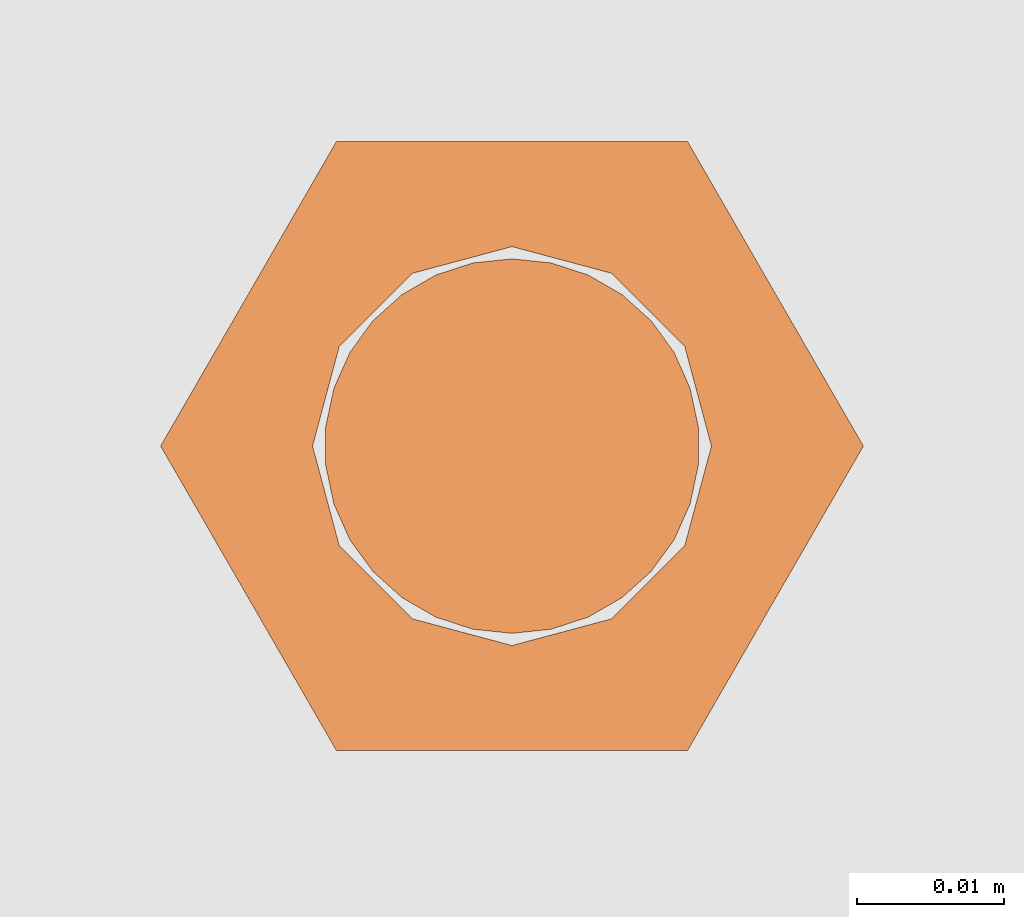
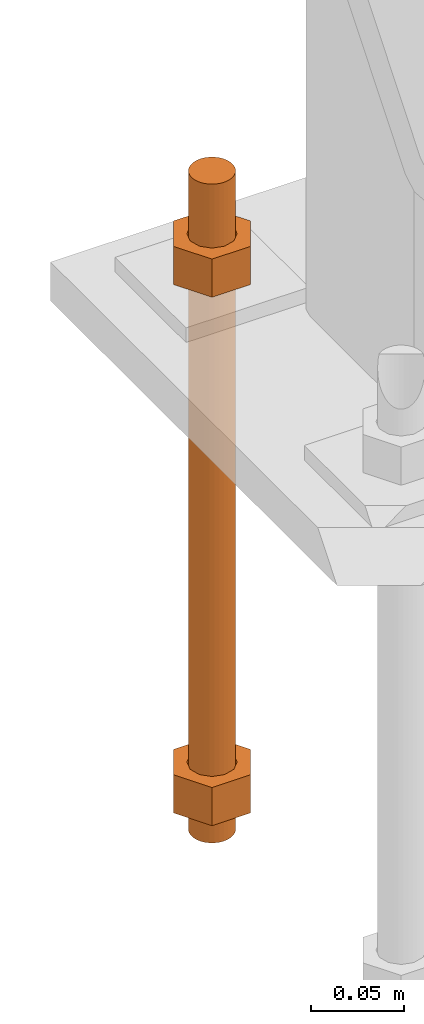
# One storey, part 25 of 89: 1 proxy.
"""IFC4 building model written with IfcOpenShell, lengths in feet."""

from ifc_helpers import new_model, entity, si_unit, converted_unit, derived_unit, direction, frame, origin, place, context, subcontext, project, spatial, faceted_brep, source, transform, mapped, material, constituent, constituent_set, type_object, type_shapes, element, save


model = new_model("IFC4")

# Units and contexts
model_context = context("Model", 3, precision=0.0001, world=origin(), true_north=direction((6.12303176911189e-17, 1.0)))
body_context = subcontext(model_context, "Body", "Model", "MODEL_VIEW")
ifc_project = project(units=[converted_unit("LENGTHUNIT", "FOOT", entity("IfcRatioMeasure", 0.3048), si_unit("LENGTHUNIT", "METRE"), dimensions=[1, 0, 0, 0, 0, 0, 0]), converted_unit("AREAUNIT", "SQUARE FOOT", entity("IfcRatioMeasure", 0.09290304), si_unit("AREAUNIT", "SQUARE_METRE"), dimensions=[2, 0, 0, 0, 0, 0, 0]), converted_unit("VOLUMEUNIT", "CUBIC FOOT", entity("IfcRatioMeasure", 0.028316846592), si_unit("VOLUMEUNIT", "CUBIC_METRE"), dimensions=[3, 0, 0, 0, 0, 0, 0]), si_unit("PLANEANGLEUNIT", "RADIAN"), si_unit("MASSUNIT", "GRAM", prefix="KILO"), derived_unit("MASSDENSITYUNIT", [(si_unit("MASSUNIT", "GRAM", prefix="KILO"), 1), (si_unit("LENGTHUNIT", "METRE"), -3)]), derived_unit("MOMENTOFINERTIAUNIT", [(si_unit("LENGTHUNIT", "METRE"), 4)]), si_unit("TIMEUNIT", "SECOND"), si_unit("FREQUENCYUNIT", "HERTZ"), si_unit("THERMODYNAMICTEMPERATUREUNIT", "DEGREE_CELSIUS"), derived_unit("THERMALTRANSMITTANCEUNIT", [(si_unit("MASSUNIT", "GRAM", prefix="KILO"), 1), (si_unit("THERMODYNAMICTEMPERATUREUNIT", "KELVIN"), -1), (si_unit("TIMEUNIT", "SECOND"), -3)]), derived_unit("VOLUMETRICFLOWRATEUNIT", [(si_unit("LENGTHUNIT", "METRE"), 3), (si_unit("TIMEUNIT", "SECOND"), -1)]), si_unit("ELECTRICCURRENTUNIT", "AMPERE"), si_unit("ELECTRICVOLTAGEUNIT", "VOLT"), si_unit("POWERUNIT", "WATT"), si_unit("FORCEUNIT", "NEWTON"), si_unit("ILLUMINANCEUNIT", "LUX"), si_unit("LUMINOUSFLUXUNIT", "LUMEN"), si_unit("LUMINOUSINTENSITYUNIT", "CANDELA"), derived_unit("USERDEFINED", [(si_unit("MASSUNIT", "GRAM", prefix="KILO"), -1), (si_unit("LENGTHUNIT", "METRE"), -2), (si_unit("TIMEUNIT", "SECOND"), 3), (si_unit("LUMINOUSFLUXUNIT", "LUMEN"), 1)]), derived_unit("LINEARVELOCITYUNIT", [(si_unit("LENGTHUNIT", "METRE"), 1), (si_unit("TIMEUNIT", "SECOND"), -1)]), si_unit("PRESSUREUNIT", "PASCAL"), derived_unit("USERDEFINED", [(si_unit("LENGTHUNIT", "METRE"), -2), (si_unit("MASSUNIT", "GRAM", prefix="KILO"), 1), (si_unit("TIMEUNIT", "SECOND"), -2)]), derived_unit("LINEARFORCEUNIT", [(si_unit("MASSUNIT", "GRAM", prefix="KILO"), 1), (si_unit("LENGTHUNIT", "METRE"), 1), (si_unit("TIMEUNIT", "SECOND"), -2), (si_unit("LENGTHUNIT", "METRE"), -1)]), derived_unit("PLANARFORCEUNIT", [(si_unit("MASSUNIT", "GRAM", prefix="KILO"), 1), (si_unit("LENGTHUNIT", "METRE"), 1), (si_unit("TIMEUNIT", "SECOND"), -2), (si_unit("LENGTHUNIT", "METRE"), -2)])], contexts=[model_context])

# Site, building, storey
site_placement = place(None, origin())
site = spatial("IfcSite", under=ifc_project, at=site_placement, CompositionType="ELEMENT")
building_placement = place(site_placement, frame((-472.238160486, -49.138065117, 0.0)))
building = spatial("IfcBuilding", under=site, at=building_placement, CompositionType="ELEMENT")
storey_placement = place(building_placement, origin())
storey = spatial("IfcBuildingStorey", under=building, at=storey_placement, Name="Level 1", CompositionType="ELEMENT", Elevation=0.0)

# Proxy
ifc_material_1 = material(Name="Color 7721", Category="Materials")
ifc_constituent_1 = constituent(ifc_material_1, Name="Color 7721", Category="Materials")
ifc_material_2 = material(Name="Color 7720", Category="Materials")
ifc_constituent_2 = constituent(ifc_material_2, Name="Color 7720", Category="Materials")
ifc_constituent_set = constituent_set(constituents=[ifc_constituent_1, ifc_constituent_2])
building_element_proxy_type = type_object("IfcBuildingElementProxyType", Name="rb2", PredefinedType="NOTDEFINED", material=ifc_material_1)
shared_shape = source(origin(), body_context, "Body", "Brep", [
    faceted_brep([(0.122545547339286, 0.0677083333333712, 0.0626666666666664), (0.156365697905557, 0.0677083333333712, 0.0626666666666664), (0.11727427342916, 0.135416666666742, 0.0626666666666664), (0.0390914244764247, 0.135416666666742, 0.0626666666666664), (0.0, 0.0677083333333712, 0.0626666666666664), (0.0338201505662994, 0.0677083333333712, 0.0626666666666664), (0.0397636251696838, 0.089889682526632, 0.0626666666666664), (0.0560014997595601, 0.106127557116452, 0.0626666666666664), (0.0781828489527925, 0.112071031719893, 0.0626666666666664), (0.100364198146025, 0.106127557116452, 0.0626666666666664), (0.116602072735901, 0.089889682526632, 0.0626666666666664), (0.11727427342916, 0.0, 0.0626666666666664), (0.0390914244764247, 0.0, 0.0626666666666664), (0.0397636251696838, 0.0455269841401105, 0.0626666666666664), (0.0560014997595601, 0.029289109550291, 0.0626666666666664), (0.0781828489527925, 0.0233456349468497, 0.0626666666666664), (0.100364198146025, 0.029289109550291, 0.0626666666666664), (0.116602072735901, 0.0455269841401105, 0.0626666666666664), (0.0, 0.0677083333333712, 0.144697916666667), (0.0390914244764531, 0.135416666666742, 0.144697916666667), (0.11727427342916, 0.135416666666742, 0.144697916666667), (0.156365697905585, 0.0677083333333712, 0.144697916666667), (0.117274273429189, 0.0, 0.144697916666667), (0.0390914244764247, 0.0, 0.144697916666667), (0.122545547339286, 0.0677083333333712, 0.144697916666666), (0.0338201505662994, 0.0677083333333712, 0.144697916666666), (0.0397636251696838, 0.0455269841401105, 0.144697916666666), (0.0560014997595601, 0.029289109550291, 0.144697916666666), (0.0781828489527925, 0.0233456349468497, 0.144697916666666), (0.100364198146025, 0.029289109550291, 0.144697916666666), (0.116602072735901, 0.0455269841401105, 0.144697916666666), (0.0397636251696838, 0.089889682526632, 0.144697916666666), (0.0560014997595601, 0.106127557116452, 0.144697916666666), (0.0781828489527925, 0.112071031719893, 0.144697916666666), (0.100364198146025, 0.106127557116452, 0.144697916666666), (0.116602072735901, 0.089889682526632, 0.144697916666666)], [[[0, 1, 2, 3, 4, 5, 6, 7, 8, 9, 10]], [[1, 11, 12, 4, 5, 13, 14, 15, 16, 17, 0]], [[4, 18, 19, 3]], [[3, 19, 20, 2]], [[2, 20, 21, 1]], [[1, 21, 22, 11]], [[11, 22, 23, 12]], [[12, 23, 18, 4]], [[24, 21, 22, 23, 18, 25, 26, 27, 28, 29, 30]], [[21, 20, 19, 18, 25, 31, 32, 33, 34, 35, 24]], [[25, 5, 6, 31]], [[31, 6, 7, 32]], [[32, 7, 8, 33]], [[33, 8, 9, 34]], [[34, 9, 10, 35]], [[35, 10, 0, 24]], [[24, 0, 17, 30]], [[30, 17, 16, 29]], [[29, 16, 15, 28]], [[28, 15, 14, 27]], [[27, 14, 13, 26]], [[26, 13, 5, 25]]]),
    faceted_brep([(0.0338201505662994, 0.0677083333333712, 1.28108333333333), (0.0, 0.0677083333333712, 1.28108333333333), (0.0390914244764247, 0.135416666666742, 1.28108333333333), (0.11727427342916, 0.135416666666742, 1.28108333333333), (0.156365697905557, 0.0677083333333712, 1.28108333333333), (0.122545547339286, 0.0677083333333712, 1.28108333333333), (0.116602072735901, 0.089889682526632, 1.28108333333333), (0.100364198146025, 0.106127557116452, 1.28108333333333), (0.0781828489527925, 0.112071031719893, 1.28108333333333), (0.0560014997595601, 0.106127557116452, 1.28108333333333), (0.0397636251696838, 0.089889682526632, 1.28108333333333), (0.0390914244764247, 0.0, 1.28108333333333), (0.11727427342916, 0.0, 1.28108333333333), (0.116602072735901, 0.0455269841401105, 1.28108333333333), (0.100364198146025, 0.029289109550291, 1.28108333333333), (0.0781828489527925, 0.0233456349468497, 1.28108333333333), (0.0560014997595601, 0.029289109550291, 1.28108333333333), (0.0397636251696838, 0.0455269841401105, 1.28108333333333), (0.156365697905528, 0.0677083333333712, 1.19905208333333), (0.117274273429132, 0.135416666666742, 1.19905208333333), (0.0390914244764247, 0.135416666666742, 1.19905208333333), (0.0, 0.0677083333333712, 1.19905208333333), (0.0390914244763962, 0.0, 1.19905208333333), (0.11727427342916, 0.0, 1.19905208333333), (0.0338201505662994, 0.0677083333333712, 1.19905208333333), (0.122545547339286, 0.0677083333333712, 1.19905208333333), (0.116602072735901, 0.0455269841401105, 1.19905208333333), (0.100364198146025, 0.029289109550291, 1.19905208333333), (0.0781828489527925, 0.0233456349468497, 1.19905208333333), (0.0560014997595601, 0.029289109550291, 1.19905208333333), (0.0397636251696838, 0.0455269841401105, 1.19905208333333), (0.116602072735901, 0.089889682526632, 1.19905208333333), (0.100364198146025, 0.106127557116452, 1.19905208333333), (0.0781828489527925, 0.112071031719893, 1.19905208333333), (0.0560014997595601, 0.106127557116452, 1.19905208333333), (0.0397636251696838, 0.089889682526632, 1.19905208333333)], [[[0, 1, 2, 3, 4, 5, 6, 7, 8, 9, 10]], [[1, 11, 12, 4, 5, 13, 14, 15, 16, 17, 0]], [[4, 18, 19, 3]], [[3, 19, 20, 2]], [[2, 20, 21, 1]], [[1, 21, 22, 11]], [[11, 22, 23, 12]], [[12, 23, 18, 4]], [[24, 21, 22, 23, 18, 25, 26, 27, 28, 29, 30]], [[21, 20, 19, 18, 25, 31, 32, 33, 34, 35, 24]], [[25, 5, 6, 31]], [[31, 6, 7, 32]], [[32, 7, 8, 33]], [[33, 8, 9, 34]], [[34, 9, 10, 35]], [[35, 10, 0, 24]], [[24, 0, 17, 30]], [[30, 17, 16, 29]], [[29, 16, 15, 28]], [[28, 15, 14, 27]], [[27, 14, 13, 26]], [[26, 13, 5, 25]]]),
    faceted_brep([(0.0781828489527925, 0.0260416666667425, 0.0), (0.0695198618353743, 0.0269521833027966, 0.0), (0.0612354888246216, 0.029643939264929, 0.0), (0.0536917967739328, 0.0339992919010683, 0.0), (0.0472184812245757, 0.0398278914017283, 0.0), (0.0420984571284464, 0.046875, 0.0), (0.0385554941071575, 0.0548326252344395, 0.0), (0.0367444366457903, 0.0633529806972319, 0.0), (0.0367444366457903, 0.0720636859695105, 0.0), (0.0385554941071575, 0.0805840414323029, 0.0), (0.0420984571284464, 0.0885416666667425, 0.0), (0.0472184812245757, 0.0955887752650142, 0.0), (0.0536917967739328, 0.101417374765674, 0.0), (0.0612354888246216, 0.105772727401813, 0.0), (0.0695198618353743, 0.108464483363946, 0.0), (0.0781828489527925, 0.109375, 0.0), (0.0868458360702107, 0.108464483363946, 0.0), (0.0951302090809634, 0.105772727401813, 0.0), (0.102673901131652, 0.101417374765674, 0.0), (0.109147216681009, 0.0955887752650142, 0.0), (0.114267240777139, 0.0885416666667425, 0.0), (0.117810203798427, 0.0805840414323029, 0.0), (0.119621261259795, 0.0720636859695105, 0.0), (0.119621261259795, 0.0633529806972319, 0.0), (0.117810203798427, 0.0548326252344395, 0.0), (0.114267240777139, 0.046875, 0.0), (0.109147216681009, 0.0398278914017283, 0.0), (0.102673901131652, 0.0339992919010683, 0.0), (0.0951302090809634, 0.029643939264929, 0.0), (0.0868458360702107, 0.0269521833027966, 0.0), (0.0868458360702107, 0.0269521833027966, 1.41666666666667), (0.0951302090809634, 0.029643939264929, 1.41666666666667), (0.102673901131652, 0.0339992919010683, 1.41666666666667), (0.109147216681009, 0.0398278914017283, 1.41666666666667), (0.114267240777139, 0.046875, 1.41666666666667), (0.117810203798427, 0.0548326252344395, 1.41666666666667), (0.119621261259795, 0.0633529806972319, 1.41666666666667), (0.119621261259795, 0.0720636859695105, 1.41666666666667), (0.117810203798427, 0.0805840414323029, 1.41666666666667), (0.114267240777139, 0.0885416666667425, 1.41666666666667), (0.109147216681009, 0.0955887752650142, 1.41666666666667), (0.102673901131652, 0.101417374765674, 1.41666666666667), (0.0951302090809634, 0.105772727401813, 1.41666666666667), (0.0868458360702107, 0.108464483363946, 1.41666666666667), (0.0781828489527925, 0.109375, 1.41666666666667), (0.0695198618353743, 0.108464483363946, 1.41666666666667), (0.0612354888246216, 0.105772727401813, 1.41666666666667), (0.0536917967739328, 0.101417374765674, 1.41666666666667), (0.0472184812245757, 0.0955887752650142, 1.41666666666667), (0.0420984571284464, 0.0885416666667425, 1.41666666666667), (0.0385554941071575, 0.0805840414323029, 1.41666666666667), (0.0367444366457903, 0.0720636859695105, 1.41666666666667), (0.0367444366457903, 0.0633529806972319, 1.41666666666667), (0.0385554941071575, 0.0548326252344395, 1.41666666666667), (0.0420984571284464, 0.046875, 1.41666666666667), (0.0472184812245757, 0.0398278914017283, 1.41666666666667), (0.0536917967739328, 0.0339992919010683, 1.41666666666667), (0.0612354888246216, 0.029643939264929, 1.41666666666667), (0.0695198618353743, 0.0269521833027966, 1.41666666666667), (0.0781828489527925, 0.0260416666667425, 1.41666666666667), (0.0695198618353743, 0.0269521833027966, 0.25), (0.0781828489527925, 0.0260416666667425, 0.25), (0.0612354888246216, 0.029643939264929, 0.25), (0.0536917967739328, 0.0339992919010683, 0.25), (0.0472184812246326, 0.0398278914017283, 0.25), (0.0420984571284464, 0.046875, 0.25), (0.0385554941071575, 0.0548326252344395, 0.25), (0.0367444366457619, 0.0633529806972319, 0.25), (0.0367444366457903, 0.0720636859695105, 0.25), (0.0385554941071575, 0.0805840414323029, 0.25), (0.0420984571284464, 0.0885416666667425, 0.25), (0.0472184812245757, 0.0955887752650142, 0.25), (0.0536917967739612, 0.101417374765674, 0.25), (0.0612354888246216, 0.105772727401813, 0.25), (0.0695198618353743, 0.108464483363946, 0.25), (0.0781828489527925, 0.109375, 0.25), (0.0868458360702107, 0.108464483363946, 0.25), (0.0951302090809634, 0.105772727401813, 0.25), (0.102673901131652, 0.101417374765674, 0.25), (0.109147216681038, 0.0955887752650142, 0.25), (0.114267240777139, 0.0885416666667425, 0.25), (0.117810203798371, 0.0805840414323029, 0.25), (0.119621261259795, 0.0720636859695105, 0.25), (0.119621261259795, 0.0633529806972319, 0.25), (0.117810203798399, 0.0548326252344395, 0.25), (0.114267240777195, 0.046875, 0.25), (0.109147216681009, 0.0398278914017283, 0.25), (0.102673901131709, 0.0339992919010683, 0.25), (0.0951302090809634, 0.029643939264929, 0.25), (0.0868458360702107, 0.0269521833027966, 0.25), (0.0695198618353743, 0.0269521833027966, 0.916666666666667), (0.0781828489527925, 0.0260416666667425, 0.916666666666667), (0.0612354888246216, 0.029643939264929, 0.916666666666667), (0.0536917967739328, 0.0339992919010683, 0.916666666666667), (0.0472184812246326, 0.0398278914017283, 0.916666666666667), (0.0420984571284464, 0.046875, 0.916666666666667), (0.0385554941071575, 0.0548326252344395, 0.916666666666667), (0.0367444366457619, 0.0633529806972319, 0.916666666666667), (0.0367444366457903, 0.0720636859695105, 0.916666666666667), (0.0385554941071575, 0.0805840414323029, 0.916666666666667), (0.0420984571284464, 0.0885416666667425, 0.916666666666667), (0.0472184812245757, 0.0955887752650142, 0.916666666666667), (0.0536917967739612, 0.101417374765674, 0.916666666666667), (0.0612354888246216, 0.105772727401813, 0.916666666666667), (0.0695198618353743, 0.108464483363946, 0.916666666666667), (0.0781828489527925, 0.109375, 0.916666666666667), (0.0868458360702107, 0.108464483363946, 0.916666666666667), (0.0951302090809634, 0.105772727401813, 0.916666666666667), (0.102673901131652, 0.101417374765674, 0.916666666666667), (0.109147216681038, 0.0955887752650142, 0.916666666666667), (0.114267240777139, 0.0885416666667425, 0.916666666666667), (0.117810203798371, 0.0805840414323029, 0.916666666666667), (0.119621261259795, 0.0720636859695105, 0.916666666666667), (0.119621261259795, 0.0633529806972319, 0.916666666666667), (0.117810203798399, 0.0548326252344395, 0.916666666666667), (0.114267240777195, 0.046875, 0.916666666666667), (0.109147216681009, 0.0398278914017283, 0.916666666666667), (0.102673901131709, 0.0339992919010683, 0.916666666666667), (0.0951302090809634, 0.029643939264929, 0.916666666666667), (0.0868458360702107, 0.0269521833027966, 0.916666666666667)], [[[0, 1, 2, 3, 4, 5, 6, 7, 8, 9, 10, 11, 12, 13, 14, 15, 16, 17, 18, 19, 20, 21, 22, 23, 24, 25, 26, 27, 28, 29]], [[30, 31, 32, 33, 34, 35, 36, 37, 38, 39, 40, 41, 42, 43, 44, 45, 46, 47, 48, 49, 50, 51, 52, 53, 54, 55, 56, 57, 58, 59]], [[60, 1, 0, 61]], [[62, 2, 1, 60]], [[63, 3, 2, 62]], [[64, 4, 3, 63]], [[65, 5, 4, 64]], [[66, 6, 5, 65]], [[67, 7, 6, 66]], [[68, 8, 7, 67]], [[69, 9, 8, 68]], [[70, 10, 9, 69]], [[71, 11, 10, 70]], [[72, 12, 11, 71]], [[73, 13, 12, 72]], [[74, 14, 13, 73]], [[75, 15, 14, 74]], [[76, 16, 15, 75]], [[77, 17, 16, 76]], [[78, 18, 17, 77]], [[79, 19, 18, 78]], [[80, 20, 19, 79]], [[81, 21, 20, 80]], [[82, 22, 21, 81]], [[83, 23, 22, 82]], [[84, 24, 23, 83]], [[85, 25, 24, 84]], [[86, 26, 25, 85]], [[87, 27, 26, 86]], [[88, 28, 27, 87]], [[89, 29, 28, 88]], [[61, 0, 29, 89]], [[90, 60, 61, 91]], [[92, 62, 60, 90]], [[93, 63, 62, 92]], [[94, 64, 63, 93]], [[95, 65, 64, 94]], [[96, 66, 65, 95]], [[97, 67, 66, 96]], [[98, 68, 67, 97]], [[99, 69, 68, 98]], [[100, 70, 69, 99]], [[101, 71, 70, 100]], [[102, 72, 71, 101]], [[103, 73, 72, 102]], [[104, 74, 73, 103]], [[105, 75, 74, 104]], [[106, 76, 75, 105]], [[107, 77, 76, 106]], [[108, 78, 77, 107]], [[109, 79, 78, 108]], [[110, 80, 79, 109]], [[111, 81, 80, 110]], [[112, 82, 81, 111]], [[113, 83, 82, 112]], [[114, 84, 83, 113]], [[115, 85, 84, 114]], [[116, 86, 85, 115]], [[117, 87, 86, 116]], [[118, 88, 87, 117]], [[119, 89, 88, 118]], [[91, 61, 89, 119]], [[58, 90, 91, 59]], [[57, 92, 90, 58]], [[56, 93, 92, 57]], [[55, 94, 93, 56]], [[54, 95, 94, 55]], [[53, 96, 95, 54]], [[52, 97, 96, 53]], [[51, 98, 97, 52]], [[50, 99, 98, 51]], [[49, 100, 99, 50]], [[48, 101, 100, 49]], [[47, 102, 101, 48]], [[46, 103, 102, 47]], [[45, 104, 103, 46]], [[44, 105, 104, 45]], [[43, 106, 105, 44]], [[42, 107, 106, 43]], [[41, 108, 107, 42]], [[40, 109, 108, 41]], [[39, 110, 109, 40]], [[38, 111, 110, 39]], [[37, 112, 111, 38]], [[36, 113, 112, 37]], [[35, 114, 113, 36]], [[34, 115, 114, 35]], [[33, 116, 115, 34]], [[32, 117, 116, 33]], [[31, 118, 117, 32]], [[30, 119, 118, 31]], [[59, 91, 119, 30]]]),
])
type_shapes(building_element_proxy_type, [shared_shape])
proxy_placement = place(building_placement, frame((206.31765048438, 997.317708333333, -1.45833333333333)))
element("IfcBuildingElementProxy", 1, at=proxy_placement, inside=storey, type_object=building_element_proxy_type, material=ifc_constituent_set, Name="rb2 489:rb2 489", ObjectType="rb2 489:rb2 489", PredefinedType="NOTDEFINED", context=body_context, shape_type="MappedRepresentation", body=[
    mapped(shared_shape, transform((0.0, 0.0, 0.0), scale=1.0)),
])

save(model, "model.ifc")
